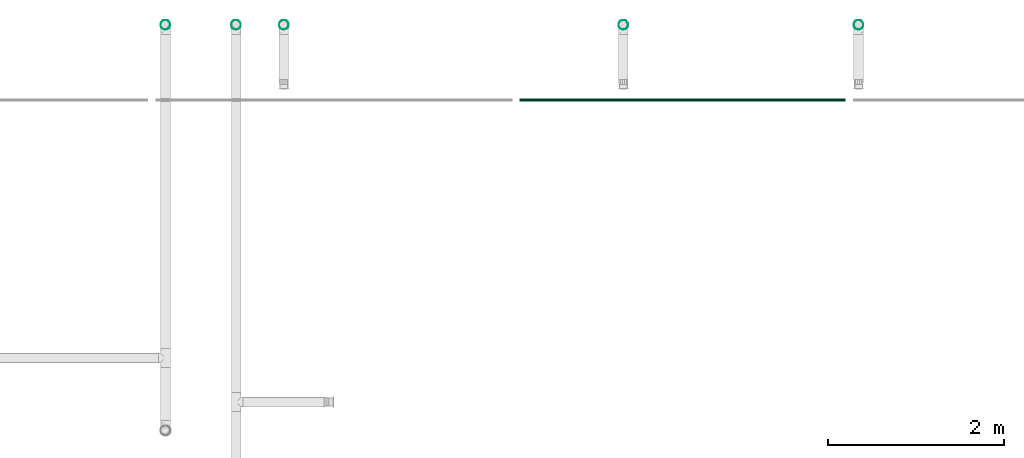
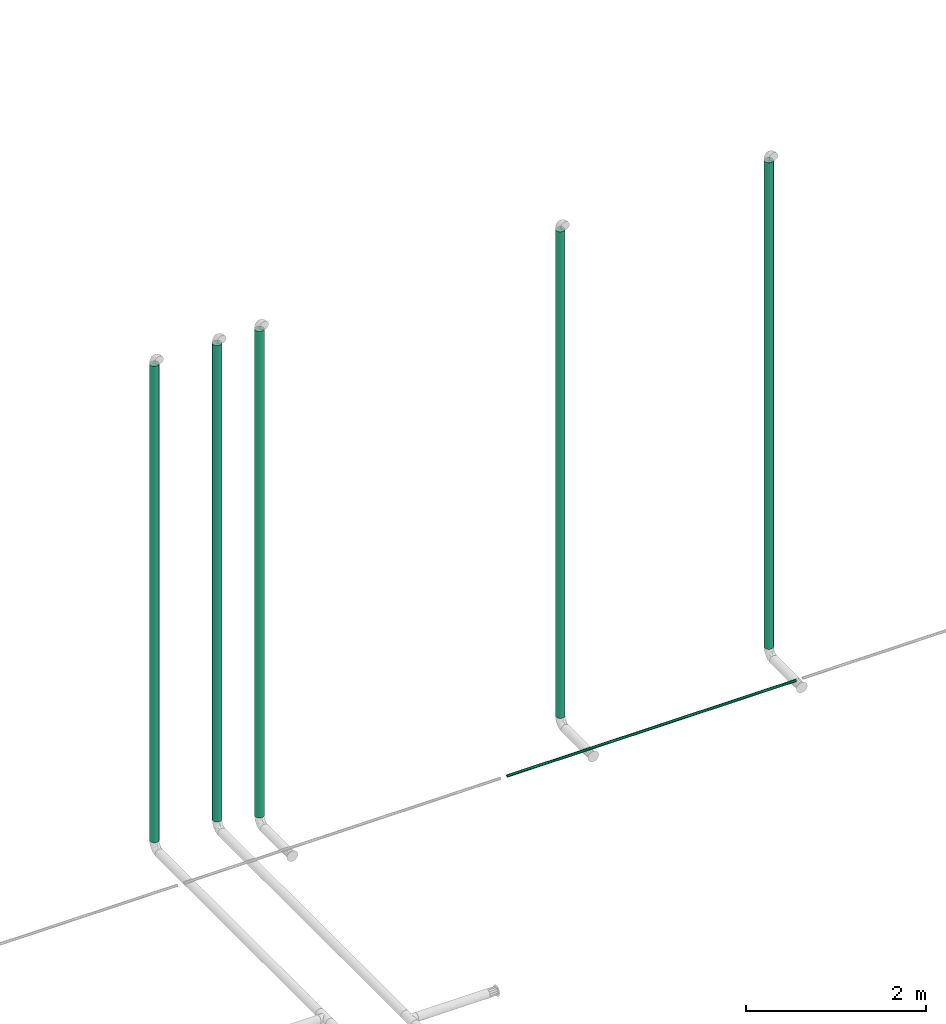
# One storey, part 17 of 123: 6 flow segments.
"""IFC2X3 building model written with IfcOpenShell, lengths in millimetres."""

import ifcopenshell
import ifcopenshell.guid

model = None  # the IFC model being written
_history = None  # IfcOwnerHistory: only IFC2X3 demands one
_inside = {}  # id of a spatial element -> (the spatial element, [elements in it])
_under = {}  # id of a project, library or spatial element -> (it, [spatial elements below it])
_declared = {}  # id of a project -> (the project, [libraries it declares])
_typed = {}  # id of a type object -> (the type object, [elements of that type])
_made_of = {}  # id of a material, layer set ... -> (it, [elements and type objects made of it])


def new_model(schema):
    """Start an empty IFC model of exactly this schema.

    Asked for "IFC4X3", IfcOpenShell would pick the latest addendum, in which some entities
    have other attributes; the version numbers below select the first issue.
    IFC2X3 requires an IfcOwnerHistory on every rooted entity: one is made here for all.
    """
    global model, _history
    if schema == "IFC4X3":
        model = ifcopenshell.file(schema_version=(4, 3, 0, 0))
    else:
        model = ifcopenshell.file(schema=schema)
    _inside.clear()
    _under.clear()
    _declared.clear()
    _typed.clear()
    _made_of.clear()
    _history = None
    if model.schema == "IFC2X3":
        org = make("IfcOrganization", Name="unknown")
        user = make(
            "IfcPersonAndOrganization",
            ThePerson=make("IfcPerson", FamilyName="unknown"),
            TheOrganization=org,
        )
        app = make(
            "IfcApplication",
            ApplicationDeveloper=org,
            Version="unknown",
            ApplicationFullName="unknown",
            ApplicationIdentifier="unknown",
        )
        _history = make(
            "IfcOwnerHistory",
            OwningUser=user,
            OwningApplication=app,
            ChangeAction="ADDED",
            CreationDate=0,
        )
    return model


def make(cls, **values):
    """One entity of the class cls with the attributes given. An attribute that is None is left unset."""
    return model.create_entity(
        cls, **{name: value for name, value in values.items() if value is not None}
    )


def entity(cls, *values):
    """Any entity or typed value of the class cls, its attributes in the order of the schema. None: left unset."""
    e = model.create_entity(cls)
    for i, value in enumerate(values):
        if value is not None:
            e[i] = value
    return e


def rooted(cls, **values):
    """An entity with a GlobalId (a new one), such as an element, a storey or a relation."""
    return make(cls, GlobalId=ifcopenshell.guid.new(), OwnerHistory=_history, **values)


def si_unit(unit_type, name, prefix=None):
    """IfcSIUnit, for example si_unit("LENGTHUNIT", "METRE", prefix="MILLI")."""
    return make("IfcSIUnit", UnitType=unit_type, Prefix=prefix, Name=name)


def converted_unit(unit_type, name, factor, base, dimensions=None, offset=None):
    """IfcConversionBasedUnit, such as the inch: factor (a typed value) times the base unit."""
    return make(
        "IfcConversionBasedUnit"
        if offset is None
        else "IfcConversionBasedUnitWithOffset",
        ConversionOffset=offset,
        Dimensions=None
        if dimensions is None
        else entity("IfcDimensionalExponents", *dimensions),
        UnitType=unit_type,
        Name=name,
        ConversionFactor=make(
            "IfcMeasureWithUnit", ValueComponent=factor, UnitComponent=base
        ),
    )


def derived_unit(unit_type, elements):
    """IfcDerivedUnit: a product of units, each with its exponent."""
    return make(
        "IfcDerivedUnit",
        Elements=[
            make("IfcDerivedUnitElement", Unit=unit, Exponent=power)
            for unit, power in elements
        ],
        UnitType=unit_type,
    )


def assignment(units):
    """IfcUnitAssignment: the units of a project."""
    return None if units is None else make("IfcUnitAssignment", Units=units)


def point(xyz):
    """IfcCartesianPoint."""
    return None if xyz is None else make("IfcCartesianPoint", Coordinates=xyz)


def direction(xyz):
    """IfcDirection."""
    return None if xyz is None else make("IfcDirection", DirectionRatios=xyz)


def frame(location, z_axis=None, x_axis=None):
    """IfcAxis2Placement3D, a coordinate frame: its origin and axes. An axis left out is left unset."""
    return make(
        "IfcAxis2Placement3D",
        Location=point(location),
        Axis=direction(z_axis),
        RefDirection=direction(x_axis),
    )


def frame_2d(location, x_axis=None):
    """IfcAxis2Placement2D, a coordinate frame in the plane: its origin and x axis."""
    return make(
        "IfcAxis2Placement2D", Location=point(location), RefDirection=direction(x_axis)
    )


def origin_with_axes():
    """The frame at (0, 0, 0) with the z axis (0, 0, 1) and the x axis (1, 0, 0) written out."""
    return frame((0.0, 0.0, 0.0), z_axis=(0.0, 0.0, 1.0), x_axis=(1.0, 0.0, 0.0))


def origin_2d_with_axis():
    """The frame at (0, 0) in the plane with the x axis (1, 0) written out."""
    return frame_2d((0.0, 0.0), x_axis=(1.0, 0.0))


def place(relative_to, where):
    """IfcLocalPlacement: puts the frame where relative to a parent placement (None: the world)."""
    return make(
        "IfcLocalPlacement", PlacementRelTo=relative_to, RelativePlacement=where
    )


def context(
    kind, dimensions, precision=None, world=None, true_north=None, identifier=None
):
    """IfcGeometricRepresentationContext, for example the 3D "Model" context."""
    return make(
        "IfcGeometricRepresentationContext",
        ContextIdentifier=identifier,
        ContextType=kind,
        CoordinateSpaceDimension=dimensions,
        Precision=precision,
        WorldCoordinateSystem=world,
        TrueNorth=true_north,
    )


def subcontext(parent, identifier, kind, view, scale=None):
    """IfcGeometricRepresentationSubContext, for example "Body" below "Model"."""
    return make(
        "IfcGeometricRepresentationSubContext",
        ContextIdentifier=identifier,
        ContextType=kind,
        ParentContext=parent,
        TargetScale=scale,
        TargetView=view,
    )


def project(units=None, contexts=None):
    """IfcProject with its units and contexts."""
    return rooted(
        "IfcProject",
        Name="project",
        RepresentationContexts=contexts,
        UnitsInContext=assignment(units),
    )


def spatial(cls, under=None, at=None, **own):
    """A site, building, storey or space (cls), placed at a placement, below another one or the project."""
    s = rooted(cls, ObjectPlacement=at, **own)
    if under is not None:
        _under.setdefault(under.id(), (under, []))[1].append(s)
    return s


def profile(cls, at=None, kind="AREA", **sizes):
    """A parametric profile (cls). Its sizes go by their IFC names, for example OverallWidth=200.0."""
    return make(cls, ProfileType=kind, Position=at, **sizes)


def hollow_circle(**sizes):
    """IfcCircleHollowProfileDef."""
    return profile("IfcCircleHollowProfileDef", **sizes)


def extrude(swept, where, along, depth):
    """IfcExtrudedAreaSolid: the profile swept, set in the frame where, extruded along a direction by depth."""
    return make(
        "IfcExtrudedAreaSolid",
        SweptArea=swept,
        Position=where,
        ExtrudedDirection=direction(along),
        Depth=depth,
    )


def shape(context_of_items, identifier, shape_type, items):
    """IfcShapeRepresentation: the items that make up one representation, for example the "Body"."""
    return make(
        "IfcShapeRepresentation",
        ContextOfItems=context_of_items,
        RepresentationIdentifier=identifier,
        RepresentationType=shape_type,
        Items=items,
    )


def source(mapping_origin, context_of_items, identifier, shape_type, items):
    """IfcRepresentationMap: a shape defined once, which mapped items show again and again."""
    return make(
        "IfcRepresentationMap",
        MappingOrigin=mapping_origin,
        MappedRepresentation=shape(context_of_items, identifier, shape_type, items),
    )


def transform(
    local_origin,
    x_axis=None,
    y_axis=None,
    z_axis=None,
    scale=None,
    scale2=None,
    scale3=None,
    uniform=True,
):
    """IfcCartesianTransformationOperator3D, or its non-uniform kind. x_axis, y_axis, z_axis: its Axis1, 2, 3."""
    if uniform:
        return make(
            "IfcCartesianTransformationOperator3D",
            Axis1=direction(x_axis),
            Axis2=direction(y_axis),
            LocalOrigin=point(local_origin),
            Scale=scale,
            Axis3=direction(z_axis),
        )
    return make(
        "IfcCartesianTransformationOperator3DnonUniform",
        Axis1=direction(x_axis),
        Axis2=direction(y_axis),
        LocalOrigin=point(local_origin),
        Scale=scale,
        Axis3=direction(z_axis),
        Scale2=scale2,
        Scale3=scale3,
    )


def mapped(mapping_source, mapping_target):
    """IfcMappedItem: shows the shape of a source again, moved by a transform."""
    return make(
        "IfcMappedItem", MappingSource=mapping_source, MappingTarget=mapping_target
    )


def material(Name=None, Category=None):
    """IfcMaterial."""
    return make("IfcMaterial", Name=Name, Category=Category)


def layer(
    of_material, thickness, ventilated=None, Name=None, Category=None, Priority=None
):
    """IfcMaterialLayer: one layer of a wall or slab, of a material (None: an air gap)."""
    return make(
        "IfcMaterialLayer",
        Material=of_material,
        LayerThickness=thickness,
        IsVentilated=ventilated,
        Name=Name,
        Category=Category,
        Priority=Priority,
    )


def layer_set(layers, Name=None):
    """IfcMaterialLayerSet."""
    return make("IfcMaterialLayerSet", MaterialLayers=layers, LayerSetName=Name)


def layer_usage(for_layer_set, set_direction, sense, offset, extent=None):
    """IfcMaterialLayerSetUsage: how a layer set lies in its element."""
    return make(
        "IfcMaterialLayerSetUsage",
        ForLayerSet=for_layer_set,
        LayerSetDirection=set_direction,
        DirectionSense=sense,
        OffsetFromReferenceLine=offset,
        ReferenceExtent=extent,
    )


def made_of(thing, what):
    """Note that an element or type object is made of a material, layer set ...; save() writes the relation."""
    if what is not None:
        _made_of.setdefault(what.id(), (what, []))[1].append(thing)
    return thing


def type_object(cls, material=None, **own):
    """A type object (cls), such as IfcWallType, which elements share."""
    return made_of(rooted(cls, **own), material)


def element(
    cls,
    number,
    at=None,
    inside=None,
    cuts=None,
    type_object=None,
    material=None,
    context=None,
    identifier="Body",
    shape_type=None,
    held_by="IfcProductDefinitionShape",
    body=None,
    shapes=None,
    **own,
):
    """One element of the class cls, such as IfcWall. Its Tag is "e" and its number.

    at: its placement. inside: the storey or other place that contains it. cuts: it is an
    opening in that element (IfcRelVoidsElement). A single representation is given by context,
    identifier, shape_type and body (its items); several are given by shapes. held_by: the class
    of the entity that holds the representations. save() writes the other relations.
    """
    e = rooted(cls, Tag="e%d" % number, ObjectPlacement=at, **own)
    if body is not None:
        shapes = [shape(context, identifier, shape_type, body)]
    if shapes is not None:
        e.Representation = make(held_by, Representations=shapes)
    if inside is not None:
        _inside.setdefault(inside.id(), (inside, []))[1].append(e)
    if cuts is not None:
        rooted(
            "IfcRelVoidsElement", RelatingBuildingElement=cuts, RelatedOpeningElement=e
        )
    if type_object is not None:
        _typed.setdefault(type_object.id(), (type_object, []))[1].append(e)
    return made_of(e, material)


def aggregate(whole, parts):
    """IfcRelAggregates: a whole, such as a stair, and the parts it consists of."""
    return rooted("IfcRelAggregates", RelatingObject=whole, RelatedObjects=parts)


def save(model, path):
    """Write the relations noted so far, then the file.

    IfcRelAggregates (storeys below a building ...), IfcRelContainedInSpatialStructure (elements
    in a storey), IfcRelDefinesByType, IfcRelAssociatesMaterial and IfcRelDeclares: one each for
    every whole, place, type object, material and project.
    """
    for whole, parts in _under.values():
        aggregate(whole, parts)
    for where, things in _inside.values():
        rooted(
            "IfcRelContainedInSpatialStructure",
            RelatedElements=things,
            RelatingStructure=where,
        )
    for kind, things in _typed.values():
        rooted("IfcRelDefinesByType", RelatedObjects=things, RelatingType=kind)
    for what, things in _made_of.values():
        rooted("IfcRelAssociatesMaterial", RelatedObjects=things, RelatingMaterial=what)
    for by, libraries in _declared.values():
        rooted("IfcRelDeclares", RelatingContext=by, RelatedDefinitions=libraries)
    model.write(path)


model = new_model("IFC2X3")

# Units and contexts
model_context = context("Model", 3, precision=1e-05, world=origin_with_axes(), true_north=direction((0.0, 1.0)))
body_context = subcontext(model_context, "Body", "Model", "MODEL_VIEW")
ifc_project = project(units=[si_unit("AREAUNIT", "SQUARE_METRE"), si_unit("VOLUMEUNIT", "CUBIC_METRE", prefix="DECI"), si_unit("TIMEUNIT", "SECOND"), si_unit("THERMODYNAMICTEMPERATUREUNIT", "DEGREE_CELSIUS"), si_unit("PRESSUREUNIT", "PASCAL"), si_unit("MASSUNIT", "GRAM", prefix="KILO"), si_unit("LENGTHUNIT", "METRE", prefix="MILLI"), si_unit("POWERUNIT", "WATT"), si_unit("ELECTRICCURRENTUNIT", "AMPERE"), si_unit("ELECTRICVOLTAGEUNIT", "VOLT"), derived_unit("VOLUMETRICFLOWRATEUNIT", [(si_unit("VOLUMEUNIT", "CUBIC_METRE", prefix="DECI"), 1), (si_unit("TIMEUNIT", "SECOND"), -1)]), derived_unit("LINEARVELOCITYUNIT", [(si_unit("LENGTHUNIT", "METRE"), 1), (si_unit("TIMEUNIT", "SECOND"), -1)]), derived_unit("MASSDENSITYUNIT", [(si_unit("MASSUNIT", "GRAM", prefix="KILO"), 1), (si_unit("VOLUMEUNIT", "CUBIC_METRE"), -1)]), converted_unit("PLANEANGLEUNIT", "DEGREE", entity("IfcRatioMeasure", 0.01745), si_unit("PLANEANGLEUNIT", "RADIAN"), dimensions=[0, 0, 0, 0, 0, 0, 0])], contexts=[model_context])

# Site, building, storey
site_placement = place(None, origin_with_axes())
site = spatial("IfcSite", under=ifc_project, at=site_placement, CompositionType="ELEMENT")
building_placement = place(site_placement, origin_with_axes())
building = spatial("IfcBuilding", under=site, at=building_placement, Name="mc-building", CompositionType="ELEMENT")
storey_placement = place(building_placement, origin_with_axes())
storey = spatial("IfcBuildingStorey", under=building, at=storey_placement, Name="1. Korrus", CompositionType="ELEMENT", Elevation=0.0)

# Flow segments
ifc_material_1 = material(Name="FZ1")
ifc_layer_1 = layer(ifc_material_1, 0.0)
ifc_layer_set_1 = layer_set([ifc_layer_1], Name="FZ1")
ifc_layer_usage_1 = layer_usage(ifc_layer_set_1, "AXIS1", "POSITIVE", 0.0)
duct_segment_type = type_object("IfcDuctSegmentType", PredefinedType="RIGIDSEGMENT")
shared_shape_1 = source(origin_with_axes(), body_context, "Body", "SweptSolid", [
    extrude(hollow_circle(Radius=55.0, WallThickness=2.0, at=origin_2d_with_axis()), frame((0.0, 0.0, 0.0), z_axis=(1.0, 0.0, 0.0), x_axis=(0.0, 1.0, 0.0)), (0.0, 0.0, 1.0), 6595.0),
])
for number, where, z_axis, x_axis in (
    (1, (23447.14677, 13663.57591, 2410.0), (0.0, -1.0, 0.0), (0.0, 0.0, 1.0)),
    (2, (26120.56538, 13663.57591, 2410.0), (0.0, -1.0, 0.0), (0.0, 0.0, 1.0)),
    (3, (19589.29598, 13663.57591, 2410.0), (0.0, -1.0, 0.0), (0.0, 0.0, 1.0)),
):
    element("IfcFlowSegment", number, at=place(storey_placement, frame(where, z_axis=z_axis, x_axis=x_axis)), inside=storey, type_object=duct_segment_type, material=ifc_layer_usage_1, context=body_context, shape_type="MappedRepresentation", body=[
        mapped(shared_shape_1, transform((0.0, 0.0, 0.0), scale=1.0)),
    ])
ifc_material_2 = material(Name="Steel")
ifc_layer_2 = layer(ifc_material_2, 0.0)
ifc_layer_set_2 = layer_set([ifc_layer_2], Name="Steel")
ifc_layer_usage_2 = layer_usage(ifc_layer_set_2, "AXIS1", "POSITIVE", 0.0)
pipe_segment_type = type_object("IfcPipeSegmentType", PredefinedType="RIGIDSEGMENT")
shared_shape_2 = source(origin_with_axes(), body_context, "Body", "SweptSolid", [
    extrude(hollow_circle(Radius=17.5, WallThickness=2.0, at=origin_2d_with_axis()), frame((0.0, 0.0, 0.0), z_axis=(1.0, 0.0, 0.0), x_axis=(0.0, 1.0, 0.0)), (0.0, 0.0, 1.0), 3702.8),
])
flow_segment_placement = place(storey_placement, frame((22269.4117, 12807.91734, 2520.89768), z_axis=(0.0, 0.0, 1.0), x_axis=(1.0, 0.0, 0.0)))
element("IfcFlowSegment", 4, at=flow_segment_placement, inside=storey, type_object=pipe_segment_type, material=ifc_layer_usage_2, context=body_context, shape_type="MappedRepresentation", body=[
    mapped(shared_shape_2, transform((0.0, 0.0, 0.0), scale=1.0)),
])
shared_shape_3 = source(origin_with_axes(), body_context, "Body", "SweptSolid", [
    extrude(hollow_circle(Radius=55.0, WallThickness=2.0, at=origin_2d_with_axis()), frame((0.0, 0.0, 0.0), z_axis=(1.0, 0.0, 0.0), x_axis=(0.0, 1.0, 0.0)), (0.0, 0.0, 1.0), 6460.0),
])
for number, where, z_axis, x_axis in (
    (5, (18242.77608, 13663.57591, 2545.0), (0.0, -1.0, 0.0), (0.0, 0.0, 1.0)),
    (6, (19046.0369, 13663.57591, 2545.0), (0.0, -1.0, 0.0), (0.0, 0.0, 1.0)),
):
    element("IfcFlowSegment", number, at=place(storey_placement, frame(where, z_axis=z_axis, x_axis=x_axis)), inside=storey, type_object=duct_segment_type, material=ifc_layer_usage_1, context=body_context, shape_type="MappedRepresentation", body=[
        mapped(shared_shape_3, transform((0.0, 0.0, 0.0), scale=1.0)),
    ])

save(model, "model.ifc")
